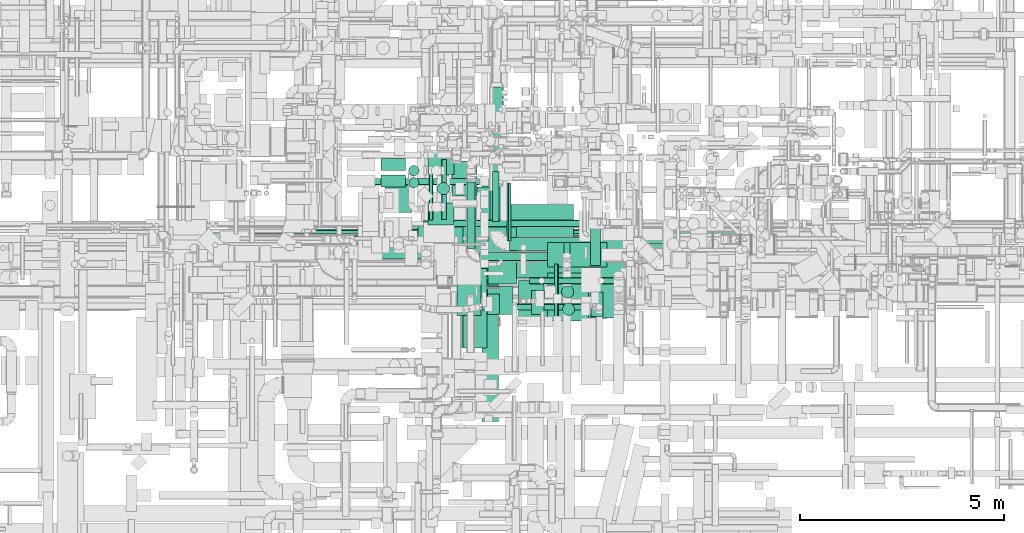
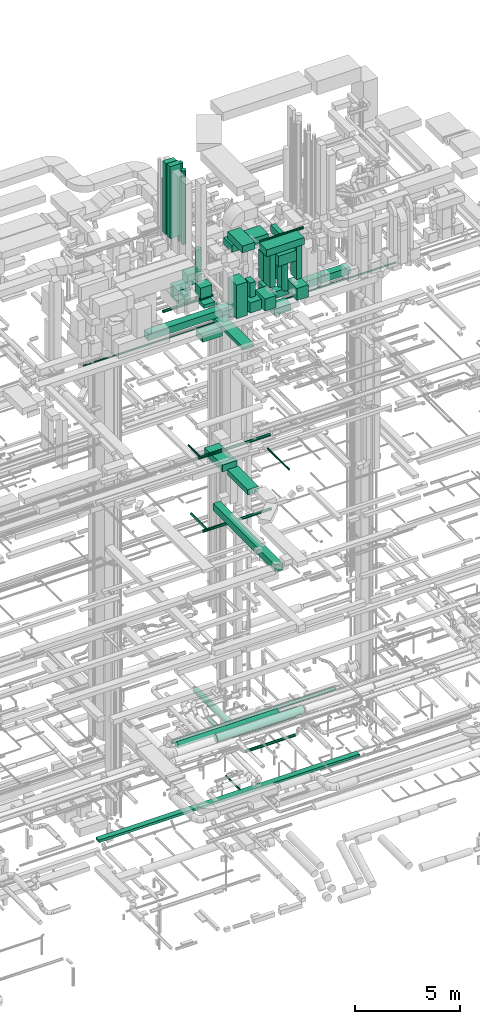
# One storey, part 44 of 337: 51 flow segments.
"""IFC2X3 building model written with IfcOpenShell, lengths in millimetres."""

from ifc_helpers import new_model, entity, si_unit, converted_unit, derived_unit, direction, frame, origin, origin_2d_with_axis, place, context, subcontext, project, spatial, rectangle, circle, extrude, type_object, element, save


model = new_model("IFC2X3")

# Units and contexts
model_context = context("Model", 3, precision=0.01, world=origin(), true_north=direction((6.12303176911189e-17, 1.0)))
body_context = subcontext(model_context, "Body", "Model", "MODEL_VIEW")
ifc_project = project(units=[si_unit("LENGTHUNIT", "METRE", prefix="MILLI"), si_unit("AREAUNIT", "SQUARE_METRE"), si_unit("VOLUMEUNIT", "CUBIC_METRE"), converted_unit("PLANEANGLEUNIT", "DEGREE", entity("IfcRatioMeasure", 0.0174532925199433), si_unit("PLANEANGLEUNIT", "RADIAN"), dimensions=[0, 0, 0, 0, 0, 0, 0]), si_unit("MASSUNIT", "GRAM", prefix="KILO"), derived_unit("MASSDENSITYUNIT", [(si_unit("MASSUNIT", "GRAM", prefix="KILO"), 1), (si_unit("LENGTHUNIT", "METRE"), -3)]), derived_unit("MOMENTOFINERTIAUNIT", [(si_unit("LENGTHUNIT", "METRE"), 4)]), si_unit("TIMEUNIT", "SECOND"), si_unit("FREQUENCYUNIT", "HERTZ"), si_unit("THERMODYNAMICTEMPERATUREUNIT", "DEGREE_CELSIUS"), derived_unit("THERMALTRANSMITTANCEUNIT", [(si_unit("MASSUNIT", "GRAM", prefix="KILO"), 1), (si_unit("THERMODYNAMICTEMPERATUREUNIT", "KELVIN"), -1), (si_unit("TIMEUNIT", "SECOND"), -3)]), derived_unit("VOLUMETRICFLOWRATEUNIT", [(si_unit("LENGTHUNIT", "METRE"), 3), (si_unit("TIMEUNIT", "SECOND"), -1)]), derived_unit("MASSFLOWRATEUNIT", [(si_unit("MASSUNIT", "GRAM", prefix="KILO"), 1), (si_unit("TIMEUNIT", "SECOND"), -1)]), derived_unit("ROTATIONALFREQUENCYUNIT", [(si_unit("TIMEUNIT", "SECOND"), -1)]), si_unit("ELECTRICCURRENTUNIT", "AMPERE"), si_unit("ELECTRICVOLTAGEUNIT", "VOLT"), si_unit("POWERUNIT", "WATT"), si_unit("FORCEUNIT", "NEWTON", prefix="KILO"), si_unit("ILLUMINANCEUNIT", "LUX"), si_unit("LUMINOUSFLUXUNIT", "LUMEN"), si_unit("LUMINOUSINTENSITYUNIT", "CANDELA"), derived_unit("USERDEFINED", [(si_unit("MASSUNIT", "GRAM", prefix="KILO"), -1), (si_unit("LENGTHUNIT", "METRE"), -2), (si_unit("TIMEUNIT", "SECOND"), 3), (si_unit("LUMINOUSFLUXUNIT", "LUMEN"), 1)]), derived_unit("LINEARVELOCITYUNIT", [(si_unit("LENGTHUNIT", "METRE"), 1), (si_unit("TIMEUNIT", "SECOND"), -1)]), si_unit("PRESSUREUNIT", "PASCAL"), derived_unit("USERDEFINED", [(si_unit("LENGTHUNIT", "METRE"), -2), (si_unit("MASSUNIT", "GRAM", prefix="KILO"), 1), (si_unit("TIMEUNIT", "SECOND"), -2)]), derived_unit("LINEARFORCEUNIT", [(si_unit("MASSUNIT", "GRAM", prefix="KILO"), 1), (si_unit("LENGTHUNIT", "METRE"), 1), (si_unit("TIMEUNIT", "SECOND"), -2), (si_unit("LENGTHUNIT", "METRE"), -1)]), derived_unit("PLANARFORCEUNIT", [(si_unit("MASSUNIT", "GRAM", prefix="KILO"), 1), (si_unit("LENGTHUNIT", "METRE"), 1), (si_unit("TIMEUNIT", "SECOND"), -2), (si_unit("LENGTHUNIT", "METRE"), -2)])], contexts=[model_context])

# Site, building, storey
site_placement = place(None, origin())
site = spatial("IfcSite", under=ifc_project, at=site_placement, CompositionType="ELEMENT")
building_placement = place(site_placement, origin())
building = spatial("IfcBuilding", under=site, at=building_placement, CompositionType="ELEMENT")
storey_placement = place(building_placement, origin())
storey = spatial("IfcBuildingStorey", under=building, at=storey_placement, CompositionType="ELEMENT", Elevation=0.0)

# Flow segments
duct_segment_type_1 = type_object("IfcDuctSegmentType", PredefinedType="NOTDEFINED")
flow_segment_1_placement = place(storey_placement, frame((43355.69, 9493.15, -650.0)))
element("IfcFlowSegment", 1, at=flow_segment_1_placement, inside=storey, type_object=duct_segment_type_1, context=body_context, shape_type="SweptSolid", body=[
    extrude(rectangle(XDim=14374.123088, YDim=300.000000000001, at=origin_2d_with_axis()), frame((7187.06, 150.0, 0.0), z_axis=(0.0, 0.0, 1.0), x_axis=(-1.0, 0.0, 0.0)), (0.0, 0.0, 1.0), 150.0),
])
flow_segment_2_placement = place(storey_placement, frame((50220.03, 7186.86, 18620.0)))
element("IfcFlowSegment", 2, at=flow_segment_2_placement, inside=storey, type_object=duct_segment_type_1, context=body_context, shape_type="SweptSolid", body=[
    extrude(rectangle(XDim=1950.33982748401, YDim=600.000000000002, at=origin_2d_with_axis()), frame((300.0, 975.17, 0.0), z_axis=(0.0, 0.0, 1.0), x_axis=(0.0, 1.0, 0.0)), (0.0, 0.0, 1.0), 300.000000000001),
])
flow_segment_3_placement = place(storey_placement, frame((50120.03, 9437.2, 18620.0)))
element("IfcFlowSegment", 3, at=flow_segment_3_placement, inside=storey, type_object=duct_segment_type_1, context=body_context, shape_type="SweptSolid", body=[
    extrude(rectangle(XDim=1698.12500000012, YDim=800.0, at=origin_2d_with_axis()), frame((400.0, 849.06, 0.0), z_axis=(0.0, 0.0, 1.0), x_axis=(0.0, 1.0, 0.0)), (0.0, 0.0, 1.0), 400.0),
])
flow_segment_4_placement = place(storey_placement, frame((50695.32, 5384.02, 15050.0)))
element("IfcFlowSegment", 4, at=flow_segment_4_placement, inside=storey, type_object=duct_segment_type_1, context=body_context, shape_type="SweptSolid", body=[
    extrude(rectangle(XDim=5951.32295065133, YDim=400.000000000004, at=origin_2d_with_axis()), frame((200.0, 2975.66, 0.0), z_axis=(0.0, 0.0, 1.0), x_axis=(0.0, -1.0, 0.0)), (0.0, 0.0, 1.0), 400.0),
])
flow_segment_5_placement = place(storey_placement, frame((49966.44, 7204.2, 27120.0)))
element("IfcFlowSegment", 5, at=flow_segment_5_placement, inside=storey, type_object=duct_segment_type_1, context=body_context, shape_type="SweptSolid", body=[
    extrude(rectangle(XDim=3332.89321881355, YDim=600.000000000002, at=origin_2d_with_axis()), frame((300.0, 1666.45, 0.0), z_axis=(0.0, 0.0, 1.0), x_axis=(0.0, 1.0, 0.0)), (0.0, 0.0, 1.0), 199.999999999998),
])
flow_segment_6_placement = place(storey_placement, frame((52852.52, 9182.55, 26920.0)))
element("IfcFlowSegment", 6, at=flow_segment_6_placement, inside=storey, type_object=duct_segment_type_1, context=body_context, shape_type="SweptSolid", body=[
    extrude(rectangle(XDim=910.589485373568, YDim=600.0, at=origin_2d_with_axis()), frame((455.29, 300.0, 0.0)), (0.0, 0.0, 1.0), 399.999999999996),
])
flow_segment_7_placement = place(storey_placement, frame((48220.03, 11539.6, 31850.0)))
element("IfcFlowSegment", 7, at=flow_segment_7_placement, inside=storey, type_object=duct_segment_type_1, context=body_context, shape_type="SweptSolid", body=[
    extrude(rectangle(XDim=600.000000000002, YDim=300.000000000001, at=origin_2d_with_axis()), frame((300.0, 150.0, 0.0), z_axis=(0.0, 0.0, 1.0), x_axis=(-1.0, 0.0, 0.0)), (0.0, 0.0, 1.0), 4130.00000000001),
])
flow_segment_8_placement = place(storey_placement, frame((48220.03, 11139.6, 31850.0)))
element("IfcFlowSegment", 8, at=flow_segment_8_placement, inside=storey, type_object=duct_segment_type_1, context=body_context, shape_type="SweptSolid", body=[
    extrude(rectangle(XDim=600.000000000002, YDim=300.000000000001, at=origin_2d_with_axis()), frame((300.0, 150.0, 0.0), z_axis=(0.0, 0.0, 1.0), x_axis=(-1.0, 0.0, 0.0)), (0.0, 0.0, 1.0), 4199.99997500001),
])
flow_segment_9_placement = place(storey_placement, frame((48310.88, 10509.01, 28400.0)))
element("IfcFlowSegment", 9, at=flow_segment_9_placement, inside=storey, type_object=duct_segment_type_1, context=body_context, shape_type="SweptSolid", body=[
    extrude(rectangle(XDim=749.999999999998, YDim=659.999999999997, at=origin_2d_with_axis()), frame((330.0, 375.0, 0.0), z_axis=(0.0, 0.0, 1.0), x_axis=(0.0, 1.0, 0.0)), (0.0, 0.0, 1.0), 769.999999999998),
])
flow_segment_10_placement = place(storey_placement, frame((50824.61, 8010.0, 29400.0)))
element("IfcFlowSegment", 10, at=flow_segment_10_placement, inside=storey, type_object=duct_segment_type_1, context=body_context, shape_type="SweptSolid", body=[
    extrude(rectangle(XDim=300.000000000001, YDim=500.0, at=origin_2d_with_axis()), frame((150.0, 250.0, 0.0), z_axis=(0.0, 0.0, 1.0), x_axis=(-1.0, 0.0, 0.0)), (0.0, 0.0, 1.0), 850.000000000032),
])
flow_segment_11_placement = place(storey_placement, frame((50073.61, 7990.0, 28450.0)))
element("IfcFlowSegment", 11, at=flow_segment_11_placement, inside=storey, type_object=duct_segment_type_1, context=body_context, shape_type="SweptSolid", body=[
    extrude(rectangle(XDim=799.999999999999, YDim=600.000000000002, at=origin_2d_with_axis()), frame((300.0, 400.0, 0.0), z_axis=(0.0, 0.0, 1.0), x_axis=(0.0, 1.0, 0.0)), (0.0, 0.0, 1.0), 1955.00000000024),
])
flow_segment_12_placement = place(storey_placement, frame((50824.61, 8010.0, 28500.0)))
element("IfcFlowSegment", 12, at=flow_segment_12_placement, inside=storey, type_object=duct_segment_type_1, context=body_context, shape_type="SweptSolid", body=[
    extrude(rectangle(XDim=700.000000000001, YDim=619.999999999998, at=origin_2d_with_axis()), frame((310.0, 350.0, 0.0), z_axis=(0.0, 0.0, 1.0), x_axis=(0.0, -1.0, 0.0)), (0.0, 0.0, 1.0), 599.999999999998),
])
flow_segment_13_placement = place(storey_placement, frame((51590.61, 7927.0, 28400.0)))
element("IfcFlowSegment", 13, at=flow_segment_13_placement, inside=storey, type_object=duct_segment_type_1, context=body_context, shape_type="SweptSolid", body=[
    extrude(rectangle(XDim=920.0, YDim=619.999999999998, at=origin_2d_with_axis()), frame((310.0, 460.0, 0.0), z_axis=(0.0, 0.0, 1.0), x_axis=(0.0, 1.0, 0.0)), (0.0, 0.0, 1.0), 699.999999999997),
])
flow_segment_14_placement = place(storey_placement, frame((51910.61, 8006.69, 29597.0)))
element("IfcFlowSegment", 14, at=flow_segment_14_placement, inside=storey, type_object=duct_segment_type_1, context=body_context, shape_type="SweptSolid", body=[
    extrude(rectangle(XDim=600.0, YDim=300.000000000001, at=origin_2d_with_axis()), frame((150.0, 300.0, 0.0), z_axis=(0.0, 0.0, 1.0), x_axis=(0.0, 1.0, 0.0)), (0.0, 0.0, 1.0), 1932.99997499978),
])
flow_segment_15_placement = place(storey_placement, frame((51683.42, 7910.0, 31550.0)))
element("IfcFlowSegment", 15, at=flow_segment_15_placement, inside=storey, type_object=duct_segment_type_1, context=body_context, shape_type="SweptSolid", body=[
    extrude(rectangle(XDim=2077.18889999996, YDim=700.0, at=origin_2d_with_axis()), frame((1038.59, 350.0, 0.0)), (0.0, 0.0, 1.0), 399.999999999996),
])
flow_segment_16_placement = place(storey_placement, frame((50833.42, 8760.0, 31550.0)))
element("IfcFlowSegment", 16, at=flow_segment_16_placement, inside=storey, type_object=duct_segment_type_1, context=body_context, shape_type="SweptSolid", body=[
    extrude(rectangle(XDim=1408.92279999999, YDim=699.999999999997, at=origin_2d_with_axis()), frame((350.0, 704.46, 0.0), z_axis=(0.0, 0.0, 1.0), x_axis=(0.0, 1.0, 0.0)), (0.0, 0.0, 1.0), 399.999999999996),
])
for number, where in (
    (17, (49369.18, 11442.75, 28500.0)),
    (18, (49369.18, 10212.75, 28500.0)),
):
    element("IfcFlowSegment", number, at=place(storey_placement, frame(where)), inside=storey, type_object=duct_segment_type_1, context=body_context, shape_type="SweptSolid", body=[
        extrude(rectangle(XDim=640.000000000002, YDim=530.000000000001, at=origin_2d_with_axis()), frame((320.0, 265.0, 0.0), z_axis=(0.0, 0.0, 1.0), x_axis=(-1.0, 0.0, 0.0)), (0.0, 0.0, 1.0), 630.000000000004),
    ])
flow_segment_17_placement = place(storey_placement, frame((52302.52, 9182.55, 27470.0)))
element("IfcFlowSegment", 19, at=flow_segment_17_placement, inside=storey, type_object=duct_segment_type_1, context=body_context, shape_type="SweptSolid", body=[
    extrude(rectangle(XDim=599.999999999999, YDim=400.000000000004, at=origin_2d_with_axis()), frame((200.0, 300.0, 0.0), z_axis=(0.0, 0.0, 1.0), x_axis=(0.0, 1.0, 0.0)), (0.0, 0.0, 1.0), 1279.98675927146),
])
flow_segment_18_placement = place(storey_placement, frame((52302.52, 9182.55, 29049.99)))
element("IfcFlowSegment", 20, at=flow_segment_18_placement, inside=storey, type_object=duct_segment_type_1, context=body_context, shape_type="SweptSolid", body=[
    extrude(rectangle(XDim=600.000000000001, YDim=999.999999999998, at=origin_2d_with_axis()), frame((500.0, 300.0, 0.0), z_axis=(0.0, 0.0, 1.0), x_axis=(0.0, -1.0, 0.0)), (0.0, 0.0, 1.0), 1600.01324072853),
])
flow_segment_19_placement = place(storey_placement, frame((52302.52, 7857.55, 30800.0)))
element("IfcFlowSegment", 21, at=flow_segment_19_placement, inside=storey, type_object=duct_segment_type_1, context=body_context, shape_type="SweptSolid", body=[
    extrude(rectangle(XDim=1175.00000000002, YDim=999.999999999998, at=origin_2d_with_axis()), frame((500.0, 587.5, 0.0), z_axis=(0.0, 0.0, 1.0), x_axis=(0.0, -1.0, 0.0)), (0.0, 0.0, 1.0), 600.000000000002),
])
flow_segment_20_placement = place(storey_placement, frame((53363.63, 7927.0, 28400.0)))
element("IfcFlowSegment", 22, at=flow_segment_20_placement, inside=storey, type_object=duct_segment_type_1, context=body_context, shape_type="SweptSolid", body=[
    extrude(rectangle(XDim=920.0, YDim=619.999999999998, at=origin_2d_with_axis()), frame((310.0, 460.0, 0.0), z_axis=(0.0, 0.0, 1.0), x_axis=(0.0, 1.0, 0.0)), (0.0, 0.0, 1.0), 699.999999999997),
])
flow_segment_21_placement = place(storey_placement, frame((53363.63, 7960.0, 29597.0)))
element("IfcFlowSegment", 23, at=flow_segment_21_placement, inside=storey, type_object=duct_segment_type_1, context=body_context, shape_type="SweptSolid", body=[
    extrude(rectangle(XDim=600.0, YDim=300.000000000001, at=origin_2d_with_axis()), frame((150.0, 300.0, 0.0), z_axis=(0.0, 0.0, 1.0), x_axis=(0.0, 1.0, 0.0)), (0.0, 0.0, 1.0), 1932.99997499978),
])
flow_segment_22_placement = place(storey_placement, frame((53350.03, 9209.24, 30900.0)))
element("IfcFlowSegment", 24, at=flow_segment_22_placement, inside=storey, type_object=duct_segment_type_1, context=body_context, shape_type="SweptSolid", body=[
    extrude(rectangle(XDim=1217.0, YDim=250.000000000004, at=origin_2d_with_axis()), frame((125.0, 608.5, 0.0), z_axis=(0.0, 0.0, 1.0), x_axis=(0.0, 1.0, 0.0)), (0.0, 0.0, 1.0), 399.999999999996),
])
flow_segment_23_placement = place(storey_placement, frame((46277.9, 9882.41, 27350.0)))
element("IfcFlowSegment", 25, at=flow_segment_23_placement, inside=storey, type_object=duct_segment_type_1, context=body_context, shape_type="SweptSolid", body=[
    extrude(rectangle(XDim=11157.6172215176, YDim=400.0, at=origin_2d_with_axis()), frame((5578.81, 200.0, 0.0), z_axis=(0.0, 0.0, 1.0), x_axis=(-1.0, 0.0, 0.0)), (0.0, 0.0, 1.0), 399.999999999996),
])
flow_segment_24_placement = place(storey_placement, frame((49966.44, 10924.2, 27300.0)))
element("IfcFlowSegment", 26, at=flow_segment_24_placement, inside=storey, type_object=duct_segment_type_1, context=body_context, shape_type="SweptSolid", body=[
    extrude(rectangle(XDim=849.440832866799, YDim=600.000000000002, at=origin_2d_with_axis()), frame((300.0, 424.72, 0.0), z_axis=(0.0, 0.0, 1.0), x_axis=(0.0, 1.0, 0.0)), (0.0, 0.0, 1.0), 199.999999999998),
])
flow_segment_25_placement = place(storey_placement, frame((49125.82, 9600.03, 26425.0)))
element("IfcFlowSegment", 27, at=flow_segment_25_placement, inside=storey, type_object=duct_segment_type_1, context=body_context, shape_type="SweptSolid", body=[
    extrude(rectangle(XDim=1100.0, YDim=650.0, at=origin_2d_with_axis()), frame((550.0, 325.0, 0.0)), (0.0, 0.0, 1.0), 349.999999999998),
])
flow_segment_26_placement = place(storey_placement, frame((50923.61, 9911.5, 30855.02)))
element("IfcFlowSegment", 28, at=flow_segment_26_placement, inside=storey, type_object=duct_segment_type_1, context=body_context, shape_type="SweptSolid", body=[
    extrude(rectangle(XDim=2010.0, YDim=800.0, at=origin_2d_with_axis()), frame((1005.0, 400.0, 0.0)), (0.0, 0.0, 1.0), 400.000000000004),
])
duct_segment_type_2 = type_object("IfcDuctSegmentType", PredefinedType="NOTDEFINED")
flow_segment_27_placement = place(storey_placement, frame((51302.68, 9813.15, -651.6)))
element("IfcFlowSegment", 29, at=flow_segment_27_placement, inside=storey, type_object=duct_segment_type_2, context=body_context, shape_type="SweptSolid", body=[
    extrude(circle(Radius=50.0, at=origin_2d_with_axis()), frame((51.6, 0.0, 51.6), z_axis=(0.0, 1.0, 0.0), x_axis=(-1.0, 0.0, 0.0)), (0.0, 0.0, 1.0), 1422.19842000003),
])
flow_segment_28_placement = place(storey_placement, frame((47645.26, 9373.4, 3360.9)))
element("IfcFlowSegment", 30, at=flow_segment_28_placement, inside=storey, type_object=duct_segment_type_2, context=body_context, shape_type="SweptSolid", body=[
    extrude(circle(Radius=157.5, at=origin_2d_with_axis()), frame((0.0, 159.1, 159.1), z_axis=(1.0, 0.0, 0.0), x_axis=(0.0, 1.0, 0.0)), (0.0, 0.0, 1.0), 5559.30302557912),
])
flow_segment_29_placement = place(storey_placement, frame((49259.89, 10155.8, 19168.4)))
element("IfcFlowSegment", 31, at=flow_segment_29_placement, inside=storey, type_object=duct_segment_type_2, context=body_context, shape_type="SweptSolid", body=[
    extrude(circle(Radius=80.0, at=origin_2d_with_axis()), frame((0.0, 81.6, 81.6), z_axis=(1.0, 0.0, 0.0), x_axis=(0.0, 1.0, 0.0)), (0.0, 0.0, 1.0), 3949.99999999999),
])
flow_segment_30_placement = place(storey_placement, frame((49393.52, 10334.85, 19128.4)))
element("IfcFlowSegment", 32, at=flow_segment_30_placement, inside=storey, type_object=duct_segment_type_2, context=body_context, shape_type="SweptSolid", body=[
    extrude(circle(Radius=50.0, at=origin_2d_with_axis()), frame((51.6, 0.0, 51.6), z_axis=(0.0, 1.0, 0.0), x_axis=(1.0, 0.0, 0.0)), (0.0, 0.0, 1.0), 1167.54064626921),
])
flow_segment_31_placement = place(storey_placement, frame((52469.41, 7211.98, 19223.4)))
element("IfcFlowSegment", 33, at=flow_segment_31_placement, inside=storey, type_object=duct_segment_type_2, context=body_context, shape_type="SweptSolid", body=[
    extrude(circle(Radius=50.0, at=origin_2d_with_axis()), frame((51.6, 0.0, 51.6), z_axis=(0.0, 1.0, 0.0), x_axis=(-1.0, 0.0, 0.0)), (0.0, 0.0, 1.0), 2038.14341585322),
])
flow_segment_32_placement = place(storey_placement, frame((49505.03, 10164.7, 14818.4)))
element("IfcFlowSegment", 34, at=flow_segment_32_placement, inside=storey, type_object=duct_segment_type_2, context=body_context, shape_type="SweptSolid", body=[
    extrude(circle(Radius=80.0, at=origin_2d_with_axis()), frame((0.0, 81.6, 81.6), z_axis=(1.0, 0.0, 0.0), x_axis=(0.0, -1.0, 0.0)), (0.0, 0.0, 1.0), 3782.02041028866),
])
flow_segment_33_placement = place(storey_placement, frame((49696.87, 10346.29, 14835.9)))
element("IfcFlowSegment", 35, at=flow_segment_33_placement, inside=storey, type_object=duct_segment_type_2, context=body_context, shape_type="SweptSolid", body=[
    extrude(circle(Radius=62.5, at=origin_2d_with_axis()), frame((64.1, 0.0, 64.1), z_axis=(0.0, 1.0, 0.0), x_axis=(1.0, 0.0, 0.0)), (0.0, 0.0, 1.0), 1467.90841325881),
])
flow_segment_34_placement = place(storey_placement, frame((47890.35, 11190.43, 27568.4)))
element("IfcFlowSegment", 36, at=flow_segment_34_placement, inside=storey, type_object=duct_segment_type_2, context=body_context, shape_type="SweptSolid", body=[
    extrude(circle(Radius=80.0, at=origin_2d_with_axis()), frame((0.0, 81.6, 81.6), z_axis=(1.0, 0.0, 0.0), x_axis=(0.0, 1.0, 0.0)), (0.0, 0.0, 1.0), 2746.27416997958),
])
flow_segment_35_placement = place(storey_placement, frame((50949.15, 10290.02, 26778.4)))
element("IfcFlowSegment", 37, at=flow_segment_35_placement, inside=storey, type_object=duct_segment_type_2, context=body_context, shape_type="SweptSolid", body=[
    extrude(circle(Radius=80.0, at=origin_2d_with_axis()), frame((81.6, 0.0, 81.6), z_axis=(0.0, 1.0, 0.0), x_axis=(1.0, 0.0, 0.0)), (0.0, 0.0, 1.0), 1233.80602930117),
])
flow_segment_36_placement = place(storey_placement, frame((48890.99, 11416.15, 31250.0)))
element("IfcFlowSegment", 38, at=flow_segment_36_placement, inside=storey, type_object=duct_segment_type_2, context=body_context, shape_type="SweptSolid", body=[
    extrude(circle(Radius=125.0, at=origin_2d_with_axis()), frame((126.6, 126.6, 0.0), z_axis=(0.0, 0.0, 1.0), x_axis=(0.0, -1.0, 0.0)), (0.0, 0.0, 1.0), 4549.99999999999),
])
flow_segment_37_placement = place(storey_placement, frame((48894.65, 11118.01, 31250.0)))
element("IfcFlowSegment", 39, at=flow_segment_37_placement, inside=storey, type_object=duct_segment_type_2, context=body_context, shape_type="SweptSolid", body=[
    extrude(circle(Radius=125.0, at=origin_2d_with_axis()), frame((126.29, 126.29, 0.0), z_axis=(0.0, 0.0, 1.0), x_axis=(0.559192903470747, 0.829037572555042, 0.0)), (0.0, 0.0, 1.0), 4300.00000000001),
])
flow_segment_38_placement = place(storey_placement, frame((49595.28, 10948.65, 28967.5)))
element("IfcFlowSegment", 40, at=flow_segment_38_placement, inside=storey, type_object=duct_segment_type_2, context=body_context, shape_type="SweptSolid", body=[
    extrude(circle(Radius=150.0, at=origin_2d_with_axis()), frame((151.6, 151.6, 0.0), z_axis=(0.0, 0.0, 1.0), x_axis=(-1.0, 0.0, 0.0)), (0.0, 0.0, 1.0), 1832.49999999999),
])
flow_segment_39_placement = place(storey_placement, frame((52641.78, 8415.77, 29105.29)))
element("IfcFlowSegment", 41, at=flow_segment_39_placement, inside=storey, type_object=duct_segment_type_2, context=body_context, shape_type="SweptSolid", body=[
    extrude(circle(Radius=150.0, at=origin_2d_with_axis()), frame((151.6, 151.6, 0.0), z_axis=(0.0, 0.0, 1.0), x_axis=(-1.0, 0.0, 0.0)), (0.0, 0.0, 1.0), 1674.70587172256),
])
flow_segment_40_placement = place(storey_placement, frame((52664.28, 7989.08, 29127.5)))
element("IfcFlowSegment", 42, at=flow_segment_40_placement, inside=storey, type_object=duct_segment_type_2, context=body_context, shape_type="SweptSolid", body=[
    extrude(circle(Radius=150.0, at=origin_2d_with_axis()), frame((151.6, 151.6, 0.0)), (0.0, 0.0, 1.0), 1652.49999999999),
])
flow_segment_41_placement = place(storey_placement, frame((47547.63, 9748.4, 3418.4)))
element("IfcFlowSegment", 43, at=flow_segment_41_placement, inside=storey, type_object=duct_segment_type_2, context=body_context, shape_type="SweptSolid", body=[
    extrude(circle(Radius=100.0, at=origin_2d_with_axis()), frame((0.0, 101.6, 101.6), z_axis=(1.0, 0.0, 0.0), x_axis=(0.0, -1.0, 0.0)), (0.0, 0.0, 1.0), 9011.05678366994),
])
flow_segment_42_placement = place(storey_placement, frame((51858.0, 8763.9, 31723.4)))
element("IfcFlowSegment", 44, at=flow_segment_42_placement, inside=storey, type_object=duct_segment_type_2, context=body_context, shape_type="SweptSolid", body=[
    extrude(circle(Radius=75.0, at=origin_2d_with_axis()), frame((0.0, 76.6, 76.6), z_axis=(1.0, 0.0, 0.0), x_axis=(0.0, 1.0, 0.0)), (0.0, 0.0, 1.0), 2380.00000000001),
])
flow_segment_43_placement = place(storey_placement, frame((49560.22, 8907.05, 3298.4)))
element("IfcFlowSegment", 45, at=flow_segment_43_placement, inside=storey, type_object=duct_segment_type_2, context=body_context, shape_type="SweptSolid", body=[
    extrude(circle(Radius=200.0, at=origin_2d_with_axis()), frame((0.0, 201.6, 201.6), z_axis=(1.0, 0.0, 0.0), x_axis=(0.0, 1.0, 0.0)), (0.0, 0.0, 1.0), 4801.18817505053),
])
flow_segment_44_placement = place(storey_placement, frame((50325.56, 9629.95, 2948.4)))
element("IfcFlowSegment", 46, at=flow_segment_44_placement, inside=storey, type_object=duct_segment_type_2, context=body_context, shape_type="SweptSolid", body=[
    extrude(circle(Radius=100.0, at=origin_2d_with_axis()), frame((101.6, 0.0, 101.6), z_axis=(0.0, 1.0, 0.0), x_axis=(1.0, 0.0, 0.0)), (0.0, 0.0, 1.0), 1636.05546720895),
])
flow_segment_45_placement = place(storey_placement, frame((50627.16, 9328.36, 2948.4)))
element("IfcFlowSegment", 47, at=flow_segment_45_placement, inside=storey, type_object=duct_segment_type_2, context=body_context, shape_type="SweptSolid", body=[
    extrude(circle(Radius=100.0, at=origin_2d_with_axis()), frame((0.0, 101.6, 101.6), z_axis=(1.0, 0.0, 0.0), x_axis=(0.0, -1.0, 0.0)), (0.0, 0.0, 1.0), 3504.75436055232),
])
flow_segment_46_placement = place(storey_placement, frame((42806.67, 9998.34, 26948.4)))
element("IfcFlowSegment", 48, at=flow_segment_46_placement, inside=storey, type_object=duct_segment_type_2, context=body_context, shape_type="SweptSolid", body=[
    extrude(circle(Radius=50.0, at=origin_2d_with_axis()), frame((0.0, 51.6, 51.6), z_axis=(1.0, 0.0, 0.0), x_axis=(0.0, -1.0, 0.0)), (0.0, 0.0, 1.0), 17242.8478816272),
])
flow_segment_47_placement = place(storey_placement, frame((50889.17, 10060.88, 2940.88)))
element("IfcFlowSegment", 49, at=flow_segment_47_placement, inside=storey, type_object=duct_segment_type_2, context=body_context, shape_type="SweptSolid", body=[
    extrude(circle(Radius=157.5, at=origin_2d_with_axis()), frame((159.1, 0.0, 159.1), z_axis=(0.0, 1.0, 1.07456912609394e-06), x_axis=(1.0, 0.0, 0.0)), (0.0, 0.0, 1.0), 3534.18874200155),
])
flow_segment_48_placement = place(storey_placement, frame((50695.81, 8118.43, 2818.4)))
element("IfcFlowSegment", 50, at=flow_segment_48_placement, inside=storey, type_object=duct_segment_type_2, context=body_context, shape_type="SweptSolid", body=[
    extrude(circle(Radius=80.0, at=origin_2d_with_axis()), frame((0.0, 81.6, 81.6), z_axis=(1.0, 0.0, 0.0), x_axis=(0.0, 1.0, 0.0)), (0.0, 0.0, 1.0), 2713.09520881661),
])
flow_segment_49_placement = place(storey_placement, frame((51363.26, 9586.79, 2940.88)))
element("IfcFlowSegment", 51, at=flow_segment_49_placement, inside=storey, type_object=duct_segment_type_2, context=body_context, shape_type="SweptSolid", body=[
    extrude(circle(Radius=157.5, at=origin_2d_with_axis()), frame((0.0, 159.1, 159.1), z_axis=(1.0, 0.0, 8.92429004954286e-06), x_axis=(0.0, -1.0, 0.0)), (0.0, 0.0, 1.0), 3050.61489077944),
])

save(model, "model.ifc")
